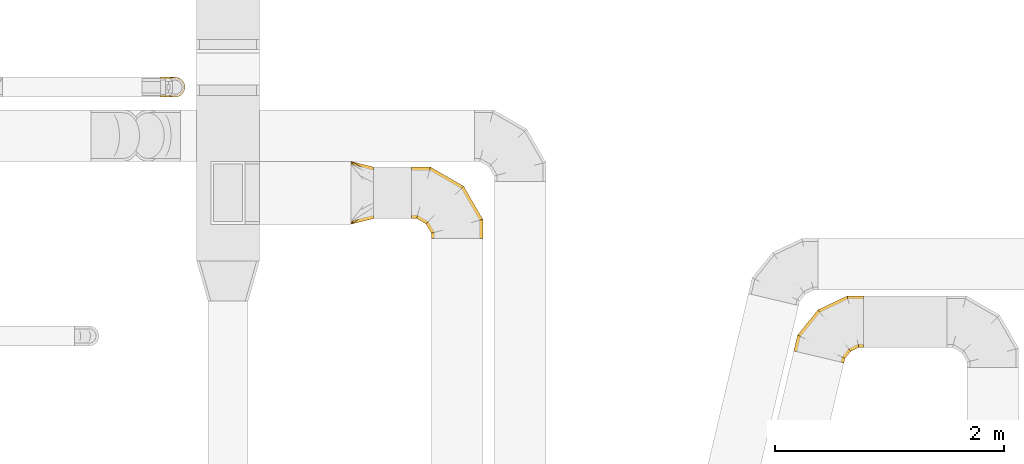
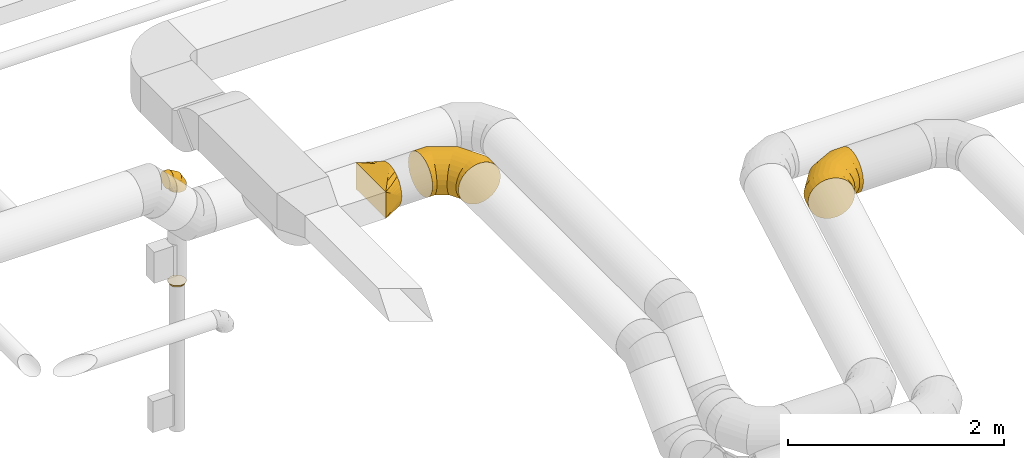
# One storey, part 16 of 97: 5 coverings.
"""IFC2X3 building model written with IfcOpenShell, lengths in millimetres."""

from ifc_helpers import new_model, entity, si_unit, converted_unit, derived_unit, direction, frame, origin, place, context, subcontext, project, spatial, faceted_brep, element, save


model = new_model("IFC2X3")

# Units and contexts
model_context = context("Model", 3, precision=0.01, world=origin(), true_north=direction((6.12303176911189e-17, 1.0)))
body_context = subcontext(model_context, "Body", "Model", "MODEL_VIEW")
ifc_project = project(units=[si_unit("LENGTHUNIT", "METRE", prefix="MILLI"), si_unit("AREAUNIT", "SQUARE_METRE"), si_unit("VOLUMEUNIT", "CUBIC_METRE"), converted_unit("PLANEANGLEUNIT", "DEGREE", entity("IfcRatioMeasure", 0.0174532925199433), si_unit("PLANEANGLEUNIT", "RADIAN"), dimensions=[0, 0, 0, 0, 0, 0, 0]), si_unit("MASSUNIT", "GRAM", prefix="KILO"), derived_unit("MASSDENSITYUNIT", [(si_unit("MASSUNIT", "GRAM", prefix="KILO"), 1), (si_unit("LENGTHUNIT", "METRE"), -3)]), derived_unit("MOMENTOFINERTIAUNIT", [(si_unit("LENGTHUNIT", "METRE"), 4)]), si_unit("TIMEUNIT", "SECOND"), si_unit("FREQUENCYUNIT", "HERTZ"), si_unit("THERMODYNAMICTEMPERATUREUNIT", "DEGREE_CELSIUS"), derived_unit("THERMALTRANSMITTANCEUNIT", [(si_unit("MASSUNIT", "GRAM", prefix="KILO"), 1), (si_unit("THERMODYNAMICTEMPERATUREUNIT", "KELVIN"), -1), (si_unit("TIMEUNIT", "SECOND"), -3)]), derived_unit("VOLUMETRICFLOWRATEUNIT", [(si_unit("LENGTHUNIT", "METRE"), 3), (si_unit("TIMEUNIT", "SECOND"), -1)]), derived_unit("MASSFLOWRATEUNIT", [(si_unit("MASSUNIT", "GRAM", prefix="KILO"), 1), (si_unit("TIMEUNIT", "SECOND"), -1)]), derived_unit("ROTATIONALFREQUENCYUNIT", [(si_unit("TIMEUNIT", "SECOND"), -1)]), si_unit("ELECTRICCURRENTUNIT", "AMPERE"), si_unit("ELECTRICVOLTAGEUNIT", "VOLT"), si_unit("POWERUNIT", "WATT"), si_unit("FORCEUNIT", "NEWTON", prefix="KILO"), si_unit("ILLUMINANCEUNIT", "LUX"), si_unit("LUMINOUSFLUXUNIT", "LUMEN"), si_unit("LUMINOUSINTENSITYUNIT", "CANDELA"), derived_unit("USERDEFINED", [(si_unit("MASSUNIT", "GRAM", prefix="KILO"), -1), (si_unit("LENGTHUNIT", "METRE"), -2), (si_unit("TIMEUNIT", "SECOND"), 3), (si_unit("LUMINOUSFLUXUNIT", "LUMEN"), 1)]), derived_unit("LINEARVELOCITYUNIT", [(si_unit("LENGTHUNIT", "METRE"), 1), (si_unit("TIMEUNIT", "SECOND"), -1)]), si_unit("PRESSUREUNIT", "PASCAL"), derived_unit("USERDEFINED", [(si_unit("LENGTHUNIT", "METRE"), -2), (si_unit("MASSUNIT", "GRAM", prefix="KILO"), 1), (si_unit("TIMEUNIT", "SECOND"), -2)]), derived_unit("LINEARFORCEUNIT", [(si_unit("MASSUNIT", "GRAM", prefix="KILO"), 1), (si_unit("LENGTHUNIT", "METRE"), 1), (si_unit("TIMEUNIT", "SECOND"), -2), (si_unit("LENGTHUNIT", "METRE"), -1)]), derived_unit("PLANARFORCEUNIT", [(si_unit("MASSUNIT", "GRAM", prefix="KILO"), 1), (si_unit("LENGTHUNIT", "METRE"), 1), (si_unit("TIMEUNIT", "SECOND"), -2), (si_unit("LENGTHUNIT", "METRE"), -2)])], contexts=[model_context])

# Site, building, storey
site_placement = place(None, origin())
site = spatial("IfcSite", under=ifc_project, at=site_placement, CompositionType="ELEMENT")
building_placement = place(site_placement, origin())
building = spatial("IfcBuilding", under=site, at=building_placement, CompositionType="ELEMENT")
storey_placement = place(building_placement, frame((0.0, 0.0, -4900.0)))
storey = spatial("IfcBuildingStorey", under=building, at=storey_placement, CompositionType="ELEMENT", Elevation=-4900.0)

# Coverings
covering_1_placement = place(storey_placement, frame((50535.84, 5948.55, 3373.4)))
element("IfcCovering", 1, at=covering_1_placement, inside=storey, PredefinedType="INSULATION", context=body_context, shape_type="Brep", body=[
    faceted_brep([(200.0, 464.32, 345.55), (200.0, 450.91, 366.88), (200.0, 433.1, 384.69), (200.0, 415.29, 402.51), (200.0, 393.95, 415.91), (200.0, 372.62, 429.31), (200.0, 348.85, 437.63), (200.0, 325.07, 445.95), (200.0, 310.85, 447.56), (200.0, 296.63, 449.16), (200.0, 275.0, 451.6), (200.0, 253.37, 449.16), (200.0, 239.15, 447.56), (200.0, 224.93, 445.95), (200.0, 201.15, 437.63), (200.0, 177.38, 429.31), (200.0, 156.05, 415.91), (200.0, 134.71, 402.51), (200.0, 116.9, 384.69), (200.0, 99.09, 366.88), (200.0, 85.68, 345.55), (200.0, 72.28, 324.22), (200.0, 63.96, 300.44), (200.0, 55.64, 276.66), (200.0, 54.04, 262.45), (200.0, 52.44, 248.23), (200.0, 50.0, 226.6), (200.0, 52.44, 204.96), (200.0, 54.04, 190.74), (200.0, 55.64, 176.53), (200.0, 63.96, 152.75), (200.0, 72.28, 128.97), (200.0, 85.68, 107.64), (200.0, 99.09, 86.31), (200.0, 116.9, 68.5), (200.0, 134.71, 50.68), (200.0, 156.05, 37.28), (200.0, 177.38, 23.88), (200.0, 201.15, 15.56), (200.0, 224.93, 7.24), (200.0, 239.15, 5.63), (200.0, 253.37, 4.03), (200.0, 275.0, 1.6), (200.0, 296.63, 4.03), (200.0, 310.85, 5.63), (200.0, 325.07, 7.24), (200.0, 348.85, 15.56), (200.0, 372.62, 23.88), (200.0, 393.95, 37.28), (200.0, 415.29, 50.68), (200.0, 433.1, 68.5), (200.0, 450.91, 86.31), (200.0, 464.32, 107.64), (200.0, 477.72, 128.97), (200.0, 486.04, 152.75), (200.0, 494.36, 176.53), (200.0, 495.96, 190.74), (200.0, 497.56, 204.96), (200.0, 500.0, 226.6), (200.0, 497.56, 248.23), (200.0, 495.96, 262.45), (200.0, 494.36, 276.66), (200.0, 486.04, 300.44), (200.0, 477.72, 324.22), (0.0, 550.0, 376.6), (0.0, 550.0, 76.6), (0.0, 0.0, 76.6), (0.0, 0.0, 376.6), (128.09, 517.98, 172.66), (104.11, 523.97, 154.68), (78.09, 442.63, 47.31), (52.06, 478.42, 57.07), (152.06, 511.99, 190.64), (164.04, 508.99, 199.63), (176.03, 505.99, 208.62), (128.09, 373.88, 28.56), (164.04, 324.44, 15.08), (152.06, 340.92, 19.57), (176.03, 307.96, 10.58), (26.03, 543.49, 96.12), (100.0, 487.09, 67.38), (26.03, 514.21, 66.83), (52.06, 536.99, 115.64), (104.11, 406.84, 37.55), (78.09, 530.48, 135.16), (26.03, 543.49, 357.07), (52.06, 536.99, 337.55), (78.09, 530.48, 318.03), (104.11, 523.97, 298.51), (128.09, 517.98, 280.53), (152.06, 511.99, 262.55), (164.04, 508.99, 253.56), (176.03, 505.99, 244.57), (128.09, 373.88, 424.63), (104.11, 406.84, 415.64), (152.06, 340.92, 433.62), (164.04, 324.44, 438.11), (176.03, 307.96, 442.61), (26.03, 514.21, 386.36), (100.0, 496.72, 376.18), (52.06, 478.42, 396.12), (78.09, 442.63, 405.88), (26.03, 35.79, 386.36), (52.06, 71.58, 396.12), (78.09, 107.37, 405.88), (104.11, 143.16, 415.64), (128.09, 176.12, 424.63), (152.06, 209.08, 433.62), (164.04, 225.56, 438.11), (176.03, 242.04, 442.61), (128.09, 32.02, 280.53), (104.11, 26.03, 298.51), (152.06, 38.01, 262.55), (164.04, 41.01, 253.56), (176.03, 44.01, 244.57), (26.03, 6.51, 357.07), (100.0, 62.91, 385.81), (52.06, 13.01, 337.55), (78.09, 19.52, 318.03), (26.03, 6.51, 96.12), (52.06, 13.01, 115.64), (78.09, 19.52, 135.16), (104.11, 26.03, 154.68), (128.09, 32.02, 172.66), (152.06, 38.01, 190.64), (164.04, 41.01, 199.63), (176.03, 44.01, 208.62), (128.09, 176.12, 28.56), (104.11, 143.16, 37.55), (152.06, 209.08, 19.57), (164.04, 225.56, 15.08), (176.03, 242.04, 10.58), (26.03, 35.79, 66.83), (100.0, 53.28, 77.01), (52.06, 71.58, 57.07), (78.09, 107.37, 47.31)], [[[0, 1, 2, 3, 4, 5, 6, 7, 8, 9, 10, 11, 12, 13, 14, 15, 16, 17, 18, 19, 20, 21, 22, 23, 24, 25, 26, 27, 28, 29, 30, 31, 32, 33, 34, 35, 36, 37, 38, 39, 40, 41, 42, 43, 44, 45, 46, 47, 48, 49, 50, 51, 52, 53, 54, 55, 56, 57, 58, 59, 60, 61, 62, 63]], [[64, 65, 66, 67]], [[68, 54, 69]], [[48, 70, 71]], [[55, 68, 72, 73, 74, 58, 57, 56]], [[45, 75, 46]], [[76, 77, 75, 45, 44, 43, 42, 78]], [[79, 51, 80]], [[80, 51, 50, 49]], [[49, 71, 81]], [[79, 82, 51]], [[47, 70, 48]], [[69, 54, 53]], [[83, 47, 46]], [[83, 46, 75]], [[68, 55, 54]], [[47, 83, 70]], [[84, 52, 82]], [[84, 69, 53]], [[65, 80, 81]], [[81, 80, 49]], [[79, 80, 65]], [[71, 49, 48]], [[52, 84, 53]], [[52, 51, 82]], [[65, 64, 85, 86, 87, 88, 89, 90, 91, 92, 58, 74, 73, 72, 68, 69, 84, 82, 79]], [[93, 6, 94]], [[0, 87, 86]], [[7, 93, 95, 96, 97, 10, 9, 8]], [[61, 89, 62]], [[91, 90, 89, 61, 60, 59, 58, 92]], [[98, 3, 99]], [[99, 3, 2, 1]], [[1, 86, 85]], [[98, 100, 3]], [[63, 87, 0]], [[94, 6, 5]], [[88, 63, 62]], [[88, 62, 89]], [[93, 7, 6]], [[63, 88, 87]], [[101, 4, 100]], [[101, 94, 5]], [[64, 99, 85]], [[85, 99, 1]], [[98, 99, 64]], [[86, 1, 0]], [[4, 101, 5]], [[4, 3, 100]], [[64, 67, 102, 103, 104, 105, 106, 107, 108, 109, 10, 97, 96, 95, 93, 94, 101, 100, 98]], [[110, 22, 111]], [[16, 104, 103]], [[23, 110, 112, 113, 114, 26, 25, 24]], [[13, 106, 14]], [[108, 107, 106, 13, 12, 11, 10, 109]], [[115, 19, 116]], [[116, 19, 18, 17]], [[17, 103, 102]], [[115, 117, 19]], [[15, 104, 16]], [[111, 22, 21]], [[105, 15, 14]], [[105, 14, 106]], [[110, 23, 22]], [[15, 105, 104]], [[118, 20, 117]], [[118, 111, 21]], [[67, 116, 102]], [[102, 116, 17]], [[115, 116, 67]], [[103, 17, 16]], [[20, 118, 21]], [[20, 19, 117]], [[67, 66, 119, 120, 121, 122, 123, 124, 125, 126, 26, 114, 113, 112, 110, 111, 118, 117, 115]], [[127, 38, 128]], [[32, 121, 120]], [[39, 127, 129, 130, 131, 42, 41, 40]], [[29, 123, 30]], [[125, 124, 123, 29, 28, 27, 26, 126]], [[132, 35, 133]], [[133, 35, 34, 33]], [[33, 120, 119]], [[132, 134, 35]], [[31, 121, 32]], [[128, 38, 37]], [[122, 31, 30]], [[122, 30, 123]], [[127, 39, 38]], [[31, 122, 121]], [[135, 36, 134]], [[135, 128, 37]], [[66, 133, 119]], [[119, 133, 33]], [[132, 133, 66]], [[120, 33, 32]], [[36, 135, 37]], [[36, 35, 134]], [[131, 130, 129, 127, 128, 135, 134, 132, 66, 65, 81, 71, 70, 83, 75, 77, 76, 78, 42]]]),
])
covering_2_placement = place(storey_placement, frame((51064.16, 5823.55, 3373.4)))
element("IfcCovering", 2, at=covering_2_placement, inside=storey, PredefinedType="INSULATION", context=body_context, shape_type="Brep", body=[
    faceted_brep([(0.0, 302.38, 429.31), (0.0, 349.93, 445.95), (0.0, 400.0, 451.6), (0.0, 450.07, 445.95), (0.0, 497.62, 429.31), (0.0, 540.29, 402.51), (0.0, 575.91, 366.88), (0.0, 602.72, 324.22), (0.0, 619.36, 276.66), (0.0, 625.0, 226.6), (0.0, 619.36, 176.53), (0.0, 602.72, 128.97), (0.0, 575.91, 86.31), (0.0, 540.29, 50.68), (0.0, 497.62, 23.88), (0.0, 450.07, 7.24), (0.0, 400.0, 1.6), (0.0, 349.93, 7.24), (0.0, 302.38, 23.88), (0.0, 259.71, 50.68), (0.0, 224.09, 86.31), (0.0, 197.28, 128.97), (0.0, 180.64, 176.53), (0.0, 175.0, 226.6), (0.0, 180.64, 276.66), (0.0, 197.28, 324.22), (0.0, 224.09, 366.88), (0.0, 259.71, 402.51), (575.91, 0.0, 86.31), (602.72, 0.0, 128.97), (619.36, 0.0, 176.53), (625.0, 0.0, 226.6), (619.36, 0.0, 276.66), (602.72, 0.0, 324.22), (575.91, 0.0, 366.88), (540.29, 0.0, 402.51), (497.62, 0.0, 429.31), (450.07, 0.0, 445.95), (400.0, 0.0, 451.6), (349.93, 0.0, 445.95), (302.38, 0.0, 429.31), (259.71, 0.0, 402.51), (224.09, 0.0, 366.88), (197.28, 0.0, 324.22), (180.64, 0.0, 276.66), (175.0, 0.0, 226.6), (180.64, 0.0, 176.53), (197.28, 0.0, 128.97), (224.09, 0.0, 86.31), (259.71, 0.0, 50.68), (302.38, 0.0, 23.88), (349.93, 0.0, 7.24), (400.0, 0.0, 1.6), (450.07, 0.0, 7.24), (497.62, 0.0, 23.88), (540.29, 0.0, 50.68), (625.0, 167.47, 226.6), (619.36, 165.96, 276.66), (602.72, 161.5, 324.22), (575.91, 154.32, 366.88), (540.29, 144.77, 402.51), (497.62, 133.34, 429.31), (450.07, 120.6, 445.95), (400.0, 107.18, 451.6), (349.93, 93.76, 445.95), (302.38, 81.02, 429.31), (259.71, 69.59, 402.51), (224.09, 60.04, 366.88), (197.28, 52.86, 324.22), (180.64, 48.4, 276.66), (175.0, 46.89, 226.6), (180.64, 48.4, 176.53), (197.28, 52.86, 128.97), (224.09, 60.04, 86.31), (259.71, 69.59, 50.68), (302.38, 81.02, 23.88), (349.93, 93.76, 7.24), (400.0, 107.18, 1.6), (450.07, 120.6, 7.24), (497.62, 133.34, 23.88), (540.29, 144.77, 50.68), (575.91, 154.32, 86.31), (602.72, 161.5, 128.97), (619.36, 165.96, 176.53), (457.53, 457.53, 226.6), (453.4, 453.4, 276.66), (441.22, 441.22, 324.22), (421.6, 421.6, 366.88), (395.52, 395.52, 402.51), (364.29, 364.29, 429.31), (329.47, 329.47, 445.95), (292.82, 292.82, 451.6), (256.17, 256.17, 445.95), (221.35, 221.35, 429.31), (190.12, 190.12, 402.51), (164.04, 164.04, 366.88), (144.42, 144.42, 324.22), (132.24, 132.24, 276.66), (128.11, 128.11, 226.6), (132.24, 132.24, 176.53), (144.42, 144.42, 128.97), (164.04, 164.04, 86.31), (190.12, 190.12, 50.68), (221.35, 221.35, 23.88), (256.17, 256.17, 7.24), (292.82, 292.82, 1.6), (329.47, 329.47, 7.24), (364.29, 364.29, 23.88), (395.52, 395.52, 50.68), (421.6, 421.6, 86.31), (441.22, 441.22, 128.97), (453.4, 453.4, 176.53), (167.47, 625.0, 226.6), (165.96, 619.36, 276.66), (161.5, 602.72, 324.22), (154.32, 575.91, 366.88), (144.77, 540.29, 402.51), (133.34, 497.62, 429.31), (120.6, 450.07, 445.95), (107.18, 400.0, 451.6), (93.76, 349.93, 445.95), (81.02, 302.38, 429.31), (69.59, 259.71, 402.51), (60.04, 224.09, 366.88), (52.86, 197.28, 324.22), (48.4, 180.64, 276.66), (46.89, 175.0, 226.6), (48.4, 180.64, 176.53), (52.86, 197.28, 128.97), (60.04, 224.09, 86.31), (69.59, 259.71, 50.68), (81.02, 302.38, 23.88), (93.76, 349.93, 7.24), (107.18, 400.0, 1.6), (120.6, 450.07, 7.24), (133.34, 497.62, 23.88), (144.77, 540.29, 50.68), (154.32, 575.91, 86.31), (161.5, 602.72, 128.97), (165.96, 619.36, 176.53)], [[[0, 1, 2, 3, 4, 5, 6, 7, 8, 9, 10, 11, 12, 13, 14, 15, 16, 17, 18, 19, 20, 21, 22, 23, 24, 25, 26, 27]], [[28, 29, 30, 31, 32, 33, 34, 35, 36, 37, 38, 39, 40, 41, 42, 43, 44, 45, 46, 47, 48, 49, 50, 51, 52, 53, 54, 55]], [[31, 56, 57, 32]], [[32, 57, 58, 33]], [[33, 58, 59, 34]], [[59, 60, 35, 34]], [[35, 60, 61, 36]], [[36, 61, 62, 37]], [[37, 62, 63, 38]], [[63, 64, 39, 38]], [[65, 66, 41, 40]], [[64, 65, 40, 39]], [[66, 67, 42, 41]], [[67, 68, 43, 42]], [[69, 70, 45, 44]], [[68, 69, 44, 43]], [[70, 71, 46, 45]], [[72, 73, 48, 47]], [[71, 72, 47, 46]], [[73, 74, 49, 48]], [[74, 75, 50, 49]], [[76, 77, 52, 51]], [[75, 76, 51, 50]], [[53, 52, 77, 78]], [[78, 79, 54, 53]], [[80, 55, 54, 79]], [[80, 81, 28, 55]], [[29, 28, 81, 82]], [[82, 83, 30, 29]], [[56, 31, 30, 83]], [[57, 56, 84, 85]], [[58, 57, 85, 86]], [[59, 58, 86, 87]], [[87, 88, 60, 59]], [[61, 60, 88, 89]], [[62, 61, 89, 90]], [[63, 62, 90, 91]], [[91, 92, 64, 63]], [[93, 94, 66, 65]], [[92, 93, 65, 64]], [[94, 95, 67, 66]], [[95, 96, 68, 67]], [[97, 98, 70, 69]], [[96, 97, 69, 68]], [[98, 99, 71, 70]], [[100, 101, 73, 72]], [[99, 100, 72, 71]], [[101, 102, 74, 73]], [[102, 103, 75, 74]], [[104, 105, 77, 76]], [[103, 104, 76, 75]], [[78, 77, 105, 106]], [[106, 107, 79, 78]], [[108, 80, 79, 107]], [[108, 109, 81, 80]], [[82, 81, 109, 110]], [[110, 111, 83, 82]], [[84, 56, 83, 111]], [[85, 84, 112, 113]], [[86, 85, 113, 114]], [[87, 86, 114, 115]], [[115, 116, 88, 87]], [[89, 88, 116, 117]], [[90, 89, 117, 118]], [[91, 90, 118, 119]], [[119, 120, 92, 91]], [[121, 122, 94, 93]], [[120, 121, 93, 92]], [[122, 123, 95, 94]], [[123, 124, 96, 95]], [[125, 126, 98, 97]], [[124, 125, 97, 96]], [[126, 127, 99, 98]], [[128, 129, 101, 100]], [[127, 128, 100, 99]], [[129, 130, 102, 101]], [[130, 131, 103, 102]], [[132, 133, 105, 104]], [[131, 132, 104, 103]], [[106, 105, 133, 134]], [[134, 135, 107, 106]], [[136, 108, 107, 135]], [[136, 137, 109, 108]], [[110, 109, 137, 138]], [[138, 139, 111, 110]], [[112, 84, 111, 139]], [[113, 112, 9, 8]], [[7, 6, 115, 114]], [[114, 113, 8, 7]], [[6, 5, 116, 115]], [[117, 116, 5, 4]], [[118, 117, 4, 3]], [[119, 118, 3, 2]], [[120, 119, 2, 1]], [[0, 27, 122, 121]], [[121, 120, 1, 0]], [[27, 26, 123, 122]], [[124, 123, 26, 25]], [[125, 124, 25, 24]], [[126, 125, 24, 23]], [[23, 22, 127, 126]], [[22, 21, 128, 127]], [[128, 21, 20, 129]], [[20, 19, 130, 129]], [[130, 19, 18, 131]], [[131, 18, 17, 132]], [[132, 17, 16, 133]], [[133, 16, 15, 134]], [[134, 15, 14, 135]], [[135, 14, 13, 136]], [[13, 12, 137, 136]], [[137, 12, 11, 138]], [[138, 11, 10, 139]], [[139, 10, 9, 112]]]),
])
covering_3_placement = place(storey_placement, frame((54403.38, 4737.06, 2723.4)))
element("IfcCovering", 3, at=covering_3_placement, inside=storey, PredefinedType="INSULATION", context=body_context, shape_type="Brep", body=[
    faceted_brep([(433.99, 2.9, 276.66), (417.8, 6.73, 324.22), (391.71, 12.91, 366.88), (357.05, 21.12, 402.51), (315.53, 30.95, 429.31), (269.26, 41.91, 445.95), (220.54, 53.45, 451.6), (171.82, 64.99, 445.95), (125.54, 75.95, 429.31), (84.03, 85.78, 402.51), (49.36, 93.99, 366.88), (23.28, 100.17, 324.22), (7.08, 104.0, 276.66), (1.6, 105.31, 226.6), (7.08, 104.0, 176.53), (23.28, 100.17, 128.97), (49.36, 93.99, 86.31), (84.03, 85.78, 50.68), (125.54, 75.95, 23.88), (171.82, 64.99, 7.24), (220.54, 53.45, 1.6), (269.26, 41.91, 7.24), (315.53, 30.95, 23.88), (357.05, 21.12, 50.68), (391.71, 12.91, 86.31), (417.8, 6.73, 128.97), (433.99, 2.9, 176.53), (439.48, 1.6, 226.6), (609.77, 537.18, 86.31), (609.77, 563.98, 128.97), (609.77, 580.62, 176.53), (609.77, 586.26, 226.6), (609.77, 580.62, 276.66), (609.77, 563.98, 324.22), (609.77, 537.18, 366.88), (609.77, 501.55, 402.51), (609.77, 458.89, 429.31), (609.77, 411.33, 445.95), (609.77, 361.26, 451.6), (609.77, 311.2, 445.95), (609.77, 263.64, 429.31), (609.77, 220.98, 402.51), (609.77, 185.35, 366.88), (609.77, 158.55, 324.22), (609.77, 141.9, 276.66), (609.77, 136.26, 226.6), (609.77, 141.9, 176.53), (609.77, 158.55, 128.97), (609.77, 185.35, 86.31), (609.77, 220.98, 50.68), (609.77, 263.64, 23.88), (609.77, 311.2, 7.24), (609.77, 361.26, 1.6), (609.77, 411.33, 7.24), (609.77, 458.89, 23.88), (609.77, 501.55, 50.68), (468.01, 586.26, 226.6), (469.29, 580.62, 276.66), (473.07, 563.98, 324.22), (479.15, 537.18, 366.88), (487.23, 501.55, 402.51), (496.9, 458.89, 429.31), (507.69, 411.33, 445.95), (519.05, 361.26, 451.6), (530.4, 311.2, 445.95), (541.19, 263.64, 429.31), (550.86, 220.98, 402.51), (558.94, 185.35, 366.88), (565.02, 158.55, 324.22), (568.8, 141.9, 276.66), (570.08, 136.26, 226.6), (568.8, 141.9, 176.53), (565.02, 158.55, 128.97), (558.94, 185.35, 86.31), (550.86, 220.98, 50.68), (541.19, 263.64, 23.88), (530.4, 311.2, 7.24), (519.05, 361.26, 1.6), (507.69, 411.33, 7.24), (496.9, 458.89, 23.88), (487.23, 501.55, 50.68), (479.15, 537.18, 86.31), (473.07, 563.98, 128.97), (469.29, 580.62, 176.53), (212.24, 463.95, 226.6), (215.83, 459.41, 276.66), (226.41, 446.02, 324.22), (243.46, 424.46, 366.88), (266.12, 395.81, 402.51), (293.26, 361.5, 429.31), (323.5, 323.25, 445.95), (355.35, 282.98, 451.6), (387.2, 242.71, 445.95), (417.44, 204.46, 429.31), (444.58, 170.15, 402.51), (467.24, 141.5, 366.88), (484.29, 119.94, 324.22), (494.87, 106.55, 276.66), (498.46, 102.01, 226.6), (494.87, 106.55, 176.53), (484.29, 119.94, 128.97), (467.24, 141.5, 86.31), (444.58, 170.15, 50.68), (417.44, 204.46, 23.88), (387.2, 242.71, 7.24), (355.35, 282.98, 1.6), (323.5, 323.25, 7.24), (293.26, 361.5, 23.88), (266.12, 395.81, 50.68), (243.46, 424.46, 86.31), (226.41, 446.02, 128.97), (215.83, 459.41, 176.53), (34.27, 243.25, 226.6), (39.46, 240.7, 276.66), (54.78, 233.19, 324.22), (79.47, 221.1, 366.88), (112.27, 205.03, 402.51), (151.55, 185.78, 429.31), (195.35, 164.32, 445.95), (241.45, 141.73, 451.6), (287.55, 119.14, 445.95), (331.34, 97.69, 429.31), (370.62, 78.44, 402.51), (403.43, 62.37, 366.88), (428.11, 50.27, 324.22), (443.43, 42.76, 276.66), (448.63, 40.22, 226.6), (443.43, 42.76, 176.53), (428.11, 50.27, 128.97), (403.43, 62.37, 86.31), (370.62, 78.44, 50.68), (331.34, 97.69, 23.88), (287.55, 119.14, 7.24), (241.45, 141.73, 1.6), (195.35, 164.32, 7.24), (151.55, 185.78, 23.88), (112.27, 205.03, 50.68), (79.47, 221.1, 86.31), (54.78, 233.19, 128.97), (39.46, 240.7, 176.53)], [[[0, 1, 2, 3, 4, 5, 6, 7, 8, 9, 10, 11, 12, 13, 14, 15, 16, 17, 18, 19, 20, 21, 22, 23, 24, 25, 26, 27]], [[28, 29, 30, 31, 32, 33, 34, 35, 36, 37, 38, 39, 40, 41, 42, 43, 44, 45, 46, 47, 48, 49, 50, 51, 52, 53, 54, 55]], [[31, 56, 57, 32]], [[32, 57, 58, 33]], [[33, 58, 59, 34]], [[59, 60, 35, 34]], [[35, 60, 61, 36]], [[36, 61, 62, 37]], [[37, 62, 63, 38]], [[63, 64, 39, 38]], [[65, 66, 41, 40]], [[64, 65, 40, 39]], [[66, 67, 42, 41]], [[67, 68, 43, 42]], [[69, 70, 45, 44]], [[68, 69, 44, 43]], [[70, 71, 46, 45]], [[72, 73, 48, 47]], [[71, 72, 47, 46]], [[73, 74, 49, 48]], [[74, 75, 50, 49]], [[76, 77, 52, 51]], [[75, 76, 51, 50]], [[53, 52, 77, 78]], [[78, 79, 54, 53]], [[80, 55, 54, 79]], [[80, 81, 28, 55]], [[29, 28, 81, 82]], [[82, 83, 30, 29]], [[56, 31, 30, 83]], [[57, 56, 84, 85]], [[57, 85, 86, 58]], [[59, 58, 86, 87]], [[87, 88, 60, 59]], [[61, 60, 88, 89]], [[62, 61, 89, 90]], [[63, 62, 90, 91]], [[91, 92, 64, 63]], [[93, 94, 66, 65]], [[92, 93, 65, 64]], [[94, 95, 67, 66]], [[95, 96, 68, 67]], [[97, 98, 70, 69]], [[96, 97, 69, 68]], [[98, 99, 71, 70]], [[100, 101, 73, 72]], [[99, 100, 72, 71]], [[101, 102, 74, 73]], [[102, 103, 75, 74]], [[104, 105, 77, 76]], [[103, 104, 76, 75]], [[78, 77, 105, 106]], [[106, 107, 79, 78]], [[108, 80, 79, 107]], [[108, 109, 81, 80]], [[82, 81, 109, 110]], [[110, 111, 83, 82]], [[84, 56, 83, 111]], [[85, 84, 112, 113]], [[85, 113, 114, 86]], [[87, 86, 114, 115]], [[115, 116, 88, 87]], [[89, 88, 116, 117]], [[90, 89, 117, 118]], [[91, 90, 118, 119]], [[119, 120, 92, 91]], [[121, 122, 94, 93]], [[120, 121, 93, 92]], [[122, 123, 95, 94]], [[123, 124, 96, 95]], [[125, 126, 98, 97]], [[124, 125, 97, 96]], [[126, 127, 99, 98]], [[128, 129, 101, 100]], [[127, 128, 100, 99]], [[129, 130, 102, 101]], [[130, 131, 103, 102]], [[132, 133, 105, 104]], [[131, 132, 104, 103]], [[106, 105, 133, 134]], [[134, 135, 107, 106]], [[136, 108, 107, 135]], [[136, 137, 109, 108]], [[110, 109, 137, 138]], [[138, 139, 111, 110]], [[112, 84, 111, 139]], [[113, 112, 13, 12]], [[11, 10, 115, 114]], [[114, 113, 12, 11]], [[10, 9, 116, 115]], [[117, 116, 9, 8]], [[118, 117, 8, 7]], [[119, 118, 7, 6]], [[120, 119, 6, 5]], [[5, 4, 121, 120]], [[3, 122, 121, 4]], [[3, 2, 123, 122]], [[124, 123, 2, 1]], [[125, 124, 1, 0]], [[126, 125, 0, 27]], [[126, 27, 26, 127]], [[26, 25, 128, 127]], [[24, 129, 128, 25]], [[24, 23, 130, 129]], [[130, 23, 22, 131]], [[131, 22, 21, 132]], [[132, 21, 20, 133]], [[133, 20, 19, 134]], [[134, 19, 18, 135]], [[135, 18, 17, 136]], [[17, 16, 137, 136]], [[137, 16, 15, 138]], [[138, 15, 14, 139]], [[139, 14, 13, 112]]]),
])
covering_4_placement = place(storey_placement, frame((48874.38, 7057.14, 3615.0)))
element("IfcCovering", 4, at=covering_4_placement, inside=storey, PredefinedType="INSULATION", context=body_context, shape_type="Brep", body=[
    faceted_brep([(97.96, 172.31, 0.0), (125.0, 176.6, 0.0), (152.04, 172.31, 0.0), (176.43, 159.88, 0.0), (195.79, 140.53, 0.0), (208.22, 116.13, 0.0), (212.5, 89.1, 0.0), (208.22, 62.06, 0.0), (195.79, 37.66, 0.0), (176.43, 18.31, 0.0), (152.04, 5.88, 0.0), (125.0, 1.6, 0.0), (97.96, 5.88, 0.0), (73.57, 18.31, 0.0), (54.21, 37.66, 0.0), (48.0, 49.86, 0.0), (41.78, 62.06, 0.0), (39.64, 75.58, 0.0), (37.5, 89.1, 0.0), (39.64, 102.61, 0.0), (41.78, 116.13, 0.0), (48.0, 128.33, 0.0), (54.21, 140.53, 0.0), (73.57, 159.88, 0.0), (0.0, 45.35, 200.78), (0.0, 66.45, 209.52), (0.0, 89.1, 212.5), (0.0, 111.74, 209.52), (0.0, 132.85, 200.78), (0.0, 150.97, 186.87), (0.0, 164.87, 168.75), (0.0, 173.61, 147.65), (0.0, 176.6, 125.0), (0.0, 173.61, 102.35), (0.0, 164.87, 81.25), (0.0, 150.97, 63.13), (0.0, 132.85, 49.22), (0.0, 111.74, 40.48), (0.0, 89.1, 37.5), (0.0, 66.45, 40.48), (0.0, 45.35, 49.22), (0.0, 27.22, 63.13), (0.0, 13.32, 81.25), (0.0, 4.58, 102.35), (0.0, 1.6, 125.0), (0.0, 4.58, 147.65), (0.0, 13.32, 168.75), (0.0, 27.22, 186.87), (56.94, 89.1, 212.5), (56.14, 111.74, 209.52), (53.8, 132.85, 200.78), (50.07, 150.97, 186.87), (45.22, 164.87, 168.75), (39.56, 173.61, 147.65), (33.49, 176.6, 125.0), (27.43, 173.61, 102.35), (21.77, 164.87, 81.25), (16.92, 150.97, 63.13), (13.19, 132.85, 49.22), (10.85, 111.74, 40.48), (10.05, 89.1, 37.5), (10.85, 66.45, 40.48), (13.19, 45.35, 49.22), (16.92, 27.22, 63.13), (27.43, 4.58, 102.35), (33.49, 1.6, 125.0), (21.77, 13.32, 81.25), (39.56, 4.58, 147.65), (45.22, 13.32, 168.75), (50.07, 27.22, 186.87), (53.8, 45.35, 200.78), (56.14, 66.45, 209.52), (155.56, 89.1, 155.56), (153.38, 111.74, 153.38), (146.98, 132.85, 146.98), (136.8, 150.97, 136.8), (123.53, 164.87, 123.53), (108.08, 173.61, 108.08), (91.51, 176.6, 91.51), (74.93, 173.61, 74.93), (59.48, 164.87, 59.48), (46.21, 150.97, 46.21), (36.03, 132.85, 36.03), (29.63, 111.74, 29.63), (27.45, 89.1, 27.45), (29.63, 66.45, 29.63), (36.03, 45.35, 36.03), (46.21, 27.22, 46.21), (74.93, 4.58, 74.93), (91.51, 1.6, 91.51), (59.48, 13.32, 59.48), (108.08, 4.58, 108.08), (123.53, 13.32, 123.53), (136.8, 27.22, 136.8), (146.98, 45.35, 146.98), (153.38, 66.45, 153.38), (212.5, 89.1, 56.94), (209.52, 111.74, 56.14), (200.78, 132.85, 53.8), (186.87, 150.97, 50.07), (168.75, 164.87, 45.22), (147.65, 173.61, 39.56), (125.0, 176.6, 33.49), (102.35, 173.61, 27.43), (81.25, 164.87, 21.77), (63.13, 150.97, 16.92), (49.22, 132.85, 13.19), (40.48, 111.74, 10.85), (38.99, 100.42, 10.45), (37.5, 89.1, 10.05), (40.48, 66.45, 10.85), (49.22, 45.35, 13.19), (38.99, 77.77, 10.45), (63.13, 27.22, 16.92), (102.35, 4.58, 27.43), (125.0, 1.6, 33.49), (81.25, 13.32, 21.77), (147.65, 4.58, 39.56), (168.75, 13.32, 45.22), (186.87, 27.22, 50.07), (200.78, 45.35, 53.8), (209.52, 66.45, 56.14)], [[[0, 1, 2, 3, 4, 5, 6, 7, 8, 9, 10, 11, 12, 13, 14, 15, 16, 17, 18, 19, 20, 21, 22, 23]], [[24, 25, 26, 27, 28, 29, 30, 31, 32, 33, 34, 35, 36, 37, 38, 39, 40, 41, 42, 43, 44, 45, 46, 47]], [[26, 48, 49, 27]], [[27, 49, 50, 28]], [[28, 50, 51, 29]], [[30, 52, 53, 31]], [[31, 53, 54, 32]], [[29, 51, 52, 30]], [[55, 56, 34, 33]], [[54, 55, 33, 32]], [[57, 35, 34, 56]], [[58, 59, 37, 36]], [[58, 36, 35, 57]], [[60, 38, 37, 59]], [[61, 62, 40, 39]], [[60, 61, 39, 38]], [[41, 40, 62, 63]], [[64, 65, 44, 43]], [[66, 64, 43, 42]], [[63, 66, 42, 41]], [[46, 45, 67, 68]], [[47, 46, 68, 69]], [[44, 65, 67, 45]], [[25, 24, 70, 71]], [[26, 25, 71, 48]], [[69, 70, 24, 47]], [[49, 48, 72, 73]], [[50, 49, 73, 74]], [[74, 75, 51, 50]], [[52, 51, 75, 76]], [[53, 52, 76, 77]], [[54, 53, 77, 78]], [[79, 80, 56, 55]], [[78, 79, 55, 54]], [[57, 56, 80, 81]], [[82, 83, 59, 58]], [[81, 82, 58, 57]], [[60, 59, 83, 84]], [[85, 86, 62, 61]], [[84, 85, 61, 60]], [[63, 62, 86, 87]], [[88, 89, 65, 64]], [[90, 88, 64, 66]], [[87, 90, 66, 63]], [[67, 65, 89, 91]], [[68, 67, 91, 92]], [[69, 68, 92, 93]], [[71, 70, 94, 95]], [[48, 71, 95, 72]], [[93, 94, 70, 69]], [[73, 72, 96, 97]], [[74, 73, 97, 98]], [[98, 99, 75, 74]], [[76, 75, 99, 100]], [[77, 76, 100, 101]], [[78, 77, 101, 102]], [[103, 104, 80, 79]], [[102, 103, 79, 78]], [[81, 80, 104, 105]], [[106, 107, 83, 82]], [[105, 106, 82, 81]], [[84, 83, 107, 108, 109]], [[110, 111, 86, 85]], [[85, 84, 109, 112, 110]], [[87, 86, 111, 113]], [[114, 115, 89, 88]], [[116, 114, 88, 90]], [[113, 116, 90, 87]], [[91, 89, 115, 117]], [[92, 91, 117, 118]], [[93, 92, 118, 119]], [[95, 94, 120, 121]], [[72, 95, 121, 96]], [[119, 120, 94, 93]], [[97, 6, 5]], [[98, 5, 4]], [[6, 97, 96]], [[97, 5, 98]], [[4, 99, 98]], [[100, 3, 2]], [[101, 2, 1]], [[99, 3, 100]], [[100, 2, 101]], [[1, 102, 101]], [[3, 99, 4]], [[103, 1, 0]], [[104, 0, 23]], [[103, 102, 1]], [[104, 103, 0]], [[23, 105, 104]], [[21, 20, 107]], [[18, 109, 108]], [[107, 20, 19]], [[106, 105, 22]], [[106, 22, 21]], [[107, 19, 108]], [[21, 107, 106]], [[18, 108, 19]], [[22, 105, 23]], [[110, 17, 16]], [[111, 15, 14]], [[18, 112, 109]], [[18, 17, 112]], [[110, 16, 15]], [[110, 15, 111]], [[14, 113, 111]], [[116, 13, 12]], [[114, 12, 11]], [[116, 113, 13]], [[115, 114, 11]], [[116, 12, 114]], [[17, 110, 112]], [[13, 113, 14]], [[117, 11, 10]], [[118, 10, 9]], [[11, 117, 115]], [[117, 10, 118]], [[9, 119, 118]], [[120, 8, 7]], [[121, 7, 6]], [[119, 8, 120]], [[121, 120, 7]], [[96, 121, 6]], [[8, 119, 9]]]),
])
covering_5_placement = place(storey_placement, frame((48910.28, 7057.14, 2540.0)))
element("IfcCovering", 5, at=covering_5_placement, inside=storey, PredefinedType="INSULATION", context=body_context, shape_type="Brep", body=[
    faceted_brep([(158.39, 117.8, 0.0), (161.24, 103.45, 0.0), (164.1, 89.1, 0.0), (161.24, 74.74, 0.0), (158.39, 60.39, 0.0), (150.26, 48.23, 0.0), (142.13, 36.06, 0.0), (129.96, 27.93, 0.0), (117.8, 19.8, 0.0), (103.45, 16.95, 0.0), (89.1, 14.1, 0.0), (74.74, 16.95, 0.0), (60.39, 19.8, 0.0), (48.23, 27.93, 0.0), (36.06, 36.06, 0.0), (27.93, 48.23, 0.0), (19.8, 60.39, 0.0), (16.95, 74.74, 0.0), (14.1, 89.1, 0.0), (16.95, 103.45, 0.0), (19.8, 117.8, 0.0), (27.93, 129.96, 0.0), (36.06, 142.13, 0.0), (48.23, 150.26, 0.0), (60.39, 158.39, 0.0), (74.74, 161.24, 0.0), (89.1, 164.1, 0.0), (103.45, 161.24, 0.0), (117.8, 158.39, 0.0), (129.96, 150.26, 0.0), (142.13, 142.13, 0.0), (150.26, 129.96, 0.0), (89.1, 176.6, 25.0), (62.06, 172.31, 25.0), (37.66, 159.88, 25.0), (18.31, 140.53, 25.0), (5.88, 116.13, 25.0), (1.6, 89.1, 25.0), (5.88, 62.06, 25.0), (18.31, 37.66, 25.0), (37.66, 18.31, 25.0), (62.06, 5.88, 25.0), (89.1, 1.6, 25.0), (116.13, 5.88, 25.0), (140.53, 18.31, 25.0), (159.88, 37.66, 25.0), (172.31, 62.06, 25.0), (176.6, 89.1, 25.0), (172.31, 116.13, 25.0), (159.88, 140.53, 25.0), (140.53, 159.88, 25.0), (116.13, 172.31, 25.0)], [[[0, 1, 2, 3, 4, 5, 6, 7, 8, 9, 10, 11, 12, 13, 14, 15, 16, 17, 18, 19, 20, 21, 22, 23, 24, 25, 26, 27, 28, 29, 30, 31]], [[32, 33, 34, 35, 36, 37, 38, 39, 40, 41, 42, 43, 44, 45, 46, 47, 48, 49, 50, 51]], [[37, 17, 38]], [[17, 37, 18]], [[16, 39, 38]], [[41, 12, 11]], [[17, 16, 38]], [[39, 16, 15, 14]], [[40, 14, 13, 12]], [[42, 11, 10]], [[41, 40, 12]], [[42, 41, 11]], [[14, 40, 39]], [[32, 25, 33]], [[25, 32, 26]], [[24, 34, 33]], [[36, 20, 19]], [[25, 24, 33]], [[34, 24, 23, 22]], [[35, 22, 21, 20]], [[37, 19, 18]], [[36, 35, 20]], [[37, 36, 19]], [[22, 35, 34]], [[47, 1, 48]], [[1, 47, 2]], [[0, 49, 48]], [[51, 28, 27]], [[1, 0, 48]], [[49, 0, 31, 30]], [[50, 30, 29, 28]], [[32, 27, 26]], [[51, 50, 28]], [[32, 51, 27]], [[30, 50, 49]], [[42, 9, 43]], [[9, 42, 10]], [[8, 44, 43]], [[46, 4, 3]], [[9, 8, 43]], [[44, 8, 7, 6]], [[45, 6, 5, 4]], [[47, 3, 2]], [[46, 45, 4]], [[47, 46, 3]], [[6, 45, 44]]]),
])

save(model, "model.ifc")
